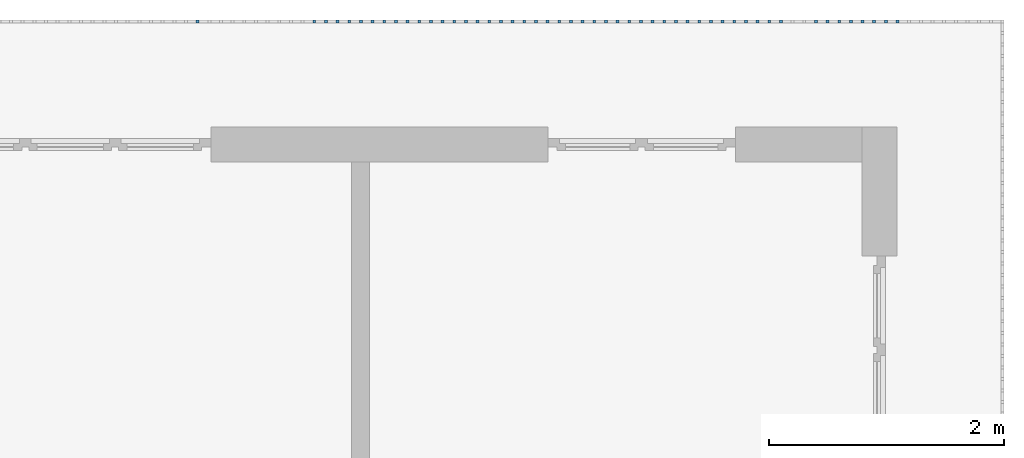
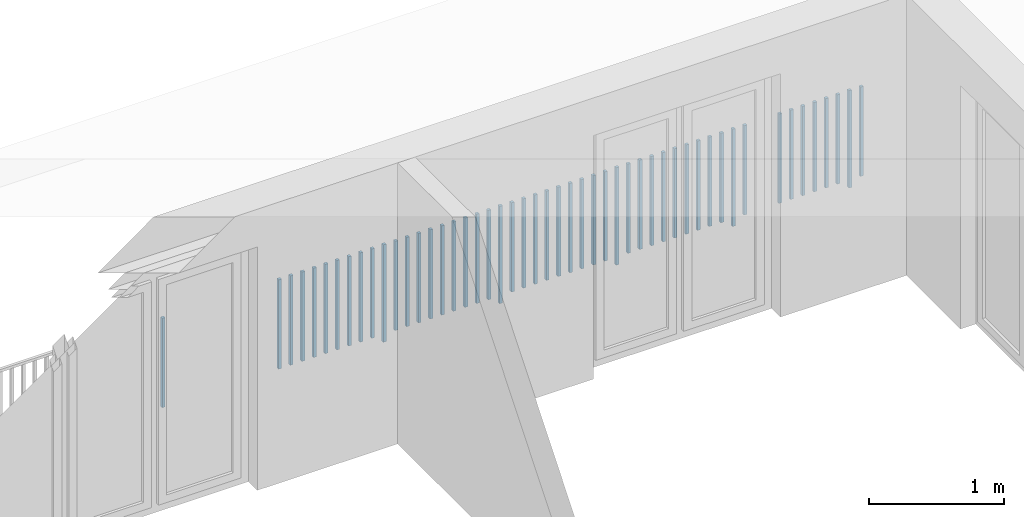
# One storey, part 53 of 54: 50 building element parts, 1 element without a shape of its own.
"""IFC4 building model written with IfcOpenShell, lengths in metres."""

from ifc_helpers import new_model, entity, si_unit, converted_unit, derived_unit, direction, frame, origin_with_axes, place, context, subcontext, project, spatial, polygons, material, type_object, element, aggregate, save


model = new_model("IFC4")

# Units and contexts
model_context = context("Model", 3, precision=1e-05, world=origin_with_axes(), true_north=direction((0.0, 1.0)))
body_context = subcontext(model_context, "Body", "Model", "MODEL_VIEW")
ifc_project = project(units=[si_unit("LENGTHUNIT", "METRE"), si_unit("AREAUNIT", "SQUARE_METRE"), si_unit("VOLUMEUNIT", "CUBIC_METRE"), converted_unit("PLANEANGLEUNIT", "DEGREE", entity("IfcPlaneAngleMeasure", 0.0174532925199), si_unit("PLANEANGLEUNIT", "RADIAN"), dimensions=[0, 0, 0, 0, 0, 0, 0]), converted_unit("TIMEUNIT", "Year", entity("IfcTimeMeasure", 31556926.0), si_unit("TIMEUNIT", "SECOND"), dimensions=[0, 0, 1, 0, 0, 0, 0]), si_unit("MASSUNIT", "GRAM", prefix="KILO"), si_unit("THERMODYNAMICTEMPERATUREUNIT", "DEGREE_CELSIUS"), si_unit("LUMINOUSINTENSITYUNIT", "LUMEN"), si_unit("ENERGYUNIT", "JOULE", prefix="MEGA"), derived_unit("THERMALCONDUCTANCEUNIT", [(si_unit("POWERUNIT", "WATT"), 1), (si_unit("LENGTHUNIT", "METRE"), -1), (si_unit("THERMODYNAMICTEMPERATUREUNIT", "KELVIN"), -1)]), derived_unit("SPECIFICHEATCAPACITYUNIT", [(si_unit("ENERGYUNIT", "JOULE"), 1), (si_unit("MASSUNIT", "GRAM", prefix="KILO"), -1), (si_unit("THERMODYNAMICTEMPERATUREUNIT", "KELVIN"), -1)]), derived_unit("MASSDENSITYUNIT", [(si_unit("MASSUNIT", "GRAM", prefix="KILO"), 1), (si_unit("VOLUMEUNIT", "CUBIC_METRE"), -1)])], contexts=[model_context])

# Site, building, storey, space
site_placement = place(None, origin_with_axes())
site = spatial("IfcSite", under=ifc_project, at=site_placement, CompositionType="ELEMENT")
building_placement = place(site_placement, origin_with_axes())
building = spatial("IfcBuilding", under=site, at=building_placement, CompositionType="ELEMENT")
storey_placement = place(building_placement, frame((0.0, 0.0, 6.29), z_axis=(0.0, 0.0, 1.0), x_axis=(1.0, 0.0, 0.0)))
storey = spatial("IfcBuildingStorey", under=building, at=storey_placement, Name="2. Geschoss", CompositionType="ELEMENT", Elevation=6.29)
space_placement = place(storey_placement, frame((10.2378006196, 9.82118769833, 0.0), z_axis=(0.0, 0.0, 1.0), x_axis=(-1.0, 0.0, 0.0)))
space = spatial("IfcSpace", under=storey, at=space_placement, CompositionType="ELEMENT", PredefinedType="EXTERNAL")

# Railing, building element parts
railing_type = type_object("IfcRailingType", PredefinedType="NOTDEFINED")
railing_placement = place(space_placement, frame((0.0, -7.06315681498e-08, 0.0), z_axis=(0.0, 0.0, 1.0), x_axis=(-1.0, 0.0, 0.0)))
railing = element("IfcRailing", 1, at=railing_placement, inside=space, type_object=railing_type, PredefinedType="NOTDEFINED")
ifc_material = material()
building_element_part_1_placement = place(railing_placement, origin_with_axes())
building_element_part_1 = element("IfcBuildingElementPart", 2, at=building_element_part_1_placement, material=ifc_material, PredefinedType="NOTDEFINED", context=body_context, shape_type="Tessellation", body=[
    polygons([(-0.907804347826, 0.0125, 0.07), (-0.907804347826, -0.0125, 0.07), (-0.907804347826, -0.0125, 0.8775), (-0.907804347826, 0.0125, 0.8775), (-0.882804347826, 0.0125, 0.07), (-0.882804347826, -0.0125, 0.07), (-0.882804347826, -0.0125, 0.8775), (-0.882804347826, 0.0125, 0.8775)], [[[1, 2, 3, 4]], [[1, 5, 6, 2]], [[2, 6, 7, 3]], [[4, 3, 7, 8]], [[5, 1, 4, 8]], [[6, 5, 8, 7]]], closed=True),
])
building_element_part_2_placement = place(railing_placement, origin_with_axes())
building_element_part_2 = element("IfcBuildingElementPart", 3, at=building_element_part_2_placement, material=ifc_material, PredefinedType="NOTDEFINED", context=body_context, shape_type="Tessellation", body=[
    polygons([(-1.0072826087, 0.0125, 0.0), (-1.0072826087, -0.0125, 0.0), (-1.0072826087, -0.0125, 0.88), (-1.0072826087, 0.0125, 0.88), (-0.982282608696, 0.0125, 0.0), (-0.982282608696, -0.0125, 0.0), (-0.982282608696, -0.0125, 0.88), (-0.982282608696, 0.0125, 0.88)], [[[1, 2, 3, 4]], [[1, 5, 6, 2]], [[2, 6, 7, 3]], [[4, 3, 7, 8]], [[5, 1, 4, 8]], [[6, 5, 8, 7]]], closed=True),
])
building_element_part_3_placement = place(railing_placement, origin_with_axes())
building_element_part_3 = element("IfcBuildingElementPart", 4, at=building_element_part_3_placement, material=ifc_material, PredefinedType="NOTDEFINED", context=body_context, shape_type="Tessellation", body=[
    polygons([(-1.10676086957, 0.0125, 0.07), (-1.10676086957, -0.0125, 0.07), (-1.10676086957, -0.0125, 0.8775), (-1.10676086957, 0.0125, 0.8775), (-1.08176086957, 0.0125, 0.07), (-1.08176086957, -0.0125, 0.07), (-1.08176086957, -0.0125, 0.8775), (-1.08176086957, 0.0125, 0.8775)], [[[1, 2, 3, 4]], [[1, 5, 6, 2]], [[2, 6, 7, 3]], [[4, 3, 7, 8]], [[5, 1, 4, 8]], [[6, 5, 8, 7]]], closed=True),
])
building_element_part_4_placement = place(railing_placement, origin_with_axes())
building_element_part_4 = element("IfcBuildingElementPart", 5, at=building_element_part_4_placement, material=ifc_material, PredefinedType="NOTDEFINED", context=body_context, shape_type="Tessellation", body=[
    polygons([(-1.20623913043, 0.0125, 0.07), (-1.20623913043, -0.0125, 0.07), (-1.20623913043, -0.0125, 0.8775), (-1.20623913043, 0.0125, 0.8775), (-1.18123913043, 0.0125, 0.07), (-1.18123913043, -0.0125, 0.07), (-1.18123913043, -0.0125, 0.8775), (-1.18123913043, 0.0125, 0.8775)], [[[1, 2, 3, 4]], [[1, 5, 6, 2]], [[2, 6, 7, 3]], [[4, 3, 7, 8]], [[5, 1, 4, 8]], [[6, 5, 8, 7]]], closed=True),
])
building_element_part_5_placement = place(railing_placement, origin_with_axes())
building_element_part_5 = element("IfcBuildingElementPart", 6, at=building_element_part_5_placement, material=ifc_material, PredefinedType="NOTDEFINED", context=body_context, shape_type="Tessellation", body=[
    polygons([(-1.3057173913, 0.0125, 0.07), (-1.3057173913, -0.0125, 0.07), (-1.3057173913, -0.0125, 0.8775), (-1.3057173913, 0.0125, 0.8775), (-1.2807173913, 0.0125, 0.07), (-1.2807173913, -0.0125, 0.07), (-1.2807173913, -0.0125, 0.8775), (-1.2807173913, 0.0125, 0.8775)], [[[1, 2, 3, 4]], [[1, 5, 6, 2]], [[2, 6, 7, 3]], [[4, 3, 7, 8]], [[5, 1, 4, 8]], [[6, 5, 8, 7]]], closed=True),
])
building_element_part_6_placement = place(railing_placement, origin_with_axes())
building_element_part_6 = element("IfcBuildingElementPart", 7, at=building_element_part_6_placement, material=ifc_material, PredefinedType="NOTDEFINED", context=body_context, shape_type="Tessellation", body=[
    polygons([(-1.40519565217, 0.0125, 0.07), (-1.40519565217, -0.0125, 0.07), (-1.40519565217, -0.0125, 0.8775), (-1.40519565217, 0.0125, 0.8775), (-1.38019565217, 0.0125, 0.07), (-1.38019565217, -0.0125, 0.07), (-1.38019565217, -0.0125, 0.8775), (-1.38019565217, 0.0125, 0.8775)], [[[1, 2, 3, 4]], [[1, 5, 6, 2]], [[2, 6, 7, 3]], [[4, 3, 7, 8]], [[5, 1, 4, 8]], [[6, 5, 8, 7]]], closed=True),
])
building_element_part_7_placement = place(railing_placement, origin_with_axes())
building_element_part_7 = element("IfcBuildingElementPart", 8, at=building_element_part_7_placement, material=ifc_material, PredefinedType="NOTDEFINED", context=body_context, shape_type="Tessellation", body=[
    polygons([(-1.50467391304, 0.0125, 0.07), (-1.50467391304, -0.0125, 0.07), (-1.50467391304, -0.0125, 0.8775), (-1.50467391304, 0.0125, 0.8775), (-1.47967391304, 0.0125, 0.07), (-1.47967391304, -0.0125, 0.07), (-1.47967391304, -0.0125, 0.8775), (-1.47967391304, 0.0125, 0.8775)], [[[1, 2, 3, 4]], [[1, 5, 6, 2]], [[2, 6, 7, 3]], [[4, 3, 7, 8]], [[5, 1, 4, 8]], [[6, 5, 8, 7]]], closed=True),
])
building_element_part_8_placement = place(railing_placement, origin_with_axes())
building_element_part_8 = element("IfcBuildingElementPart", 9, at=building_element_part_8_placement, material=ifc_material, PredefinedType="NOTDEFINED", context=body_context, shape_type="Tessellation", body=[
    polygons([(-1.60415217391, 0.0125, 0.07), (-1.60415217391, -0.0125, 0.07), (-1.60415217391, -0.0125, 0.8775), (-1.60415217391, 0.0125, 0.8775), (-1.57915217391, 0.0125, 0.07), (-1.57915217391, -0.0125, 0.07), (-1.57915217391, -0.0125, 0.8775), (-1.57915217391, 0.0125, 0.8775)], [[[1, 2, 3, 4]], [[1, 5, 6, 2]], [[2, 6, 7, 3]], [[4, 3, 7, 8]], [[5, 1, 4, 8]], [[6, 5, 8, 7]]], closed=True),
])
building_element_part_9_placement = place(railing_placement, origin_with_axes())
building_element_part_9 = element("IfcBuildingElementPart", 10, at=building_element_part_9_placement, material=ifc_material, PredefinedType="NOTDEFINED", context=body_context, shape_type="Tessellation", body=[
    polygons([(-1.90258695652, 0.0125, 0.07), (-1.90258695652, -0.0125, 0.07), (-1.90258695652, -0.0125, 0.8775), (-1.90258695652, 0.0125, 0.8775), (-1.87758695652, 0.0125, 0.07), (-1.87758695652, -0.0125, 0.07), (-1.87758695652, -0.0125, 0.8775), (-1.87758695652, 0.0125, 0.8775)], [[[1, 2, 3, 4]], [[1, 5, 6, 2]], [[2, 6, 7, 3]], [[4, 3, 7, 8]], [[5, 1, 4, 8]], [[6, 5, 8, 7]]], closed=True),
])
building_element_part_10_placement = place(railing_placement, origin_with_axes())
building_element_part_10 = element("IfcBuildingElementPart", 11, at=building_element_part_10_placement, material=ifc_material, PredefinedType="NOTDEFINED", context=body_context, shape_type="Tessellation", body=[
    polygons([(-2.00206521739, 0.0125, 0.0), (-2.00206521739, -0.0125, 0.0), (-2.00206521739, -0.0125, 0.88), (-2.00206521739, 0.0125, 0.88), (-1.97706521739, 0.0125, 0.0), (-1.97706521739, -0.0125, 0.0), (-1.97706521739, -0.0125, 0.88), (-1.97706521739, 0.0125, 0.88)], [[[1, 2, 3, 4]], [[1, 5, 6, 2]], [[2, 6, 7, 3]], [[4, 3, 7, 8]], [[5, 1, 4, 8]], [[6, 5, 8, 7]]], closed=True),
])
building_element_part_11_placement = place(railing_placement, origin_with_axes())
building_element_part_11 = element("IfcBuildingElementPart", 12, at=building_element_part_11_placement, material=ifc_material, PredefinedType="NOTDEFINED", context=body_context, shape_type="Tessellation", body=[
    polygons([(-2.10154347826, 0.0125, 0.07), (-2.10154347826, -0.0125, 0.07), (-2.10154347826, -0.0125, 0.8775), (-2.10154347826, 0.0125, 0.8775), (-2.07654347826, 0.0125, 0.07), (-2.07654347826, -0.0125, 0.07), (-2.07654347826, -0.0125, 0.8775), (-2.07654347826, 0.0125, 0.8775)], [[[1, 2, 3, 4]], [[1, 5, 6, 2]], [[2, 6, 7, 3]], [[4, 3, 7, 8]], [[5, 1, 4, 8]], [[6, 5, 8, 7]]], closed=True),
])
building_element_part_12_placement = place(railing_placement, origin_with_axes())
building_element_part_12 = element("IfcBuildingElementPart", 13, at=building_element_part_12_placement, material=ifc_material, PredefinedType="NOTDEFINED", context=body_context, shape_type="Tessellation", body=[
    polygons([(-2.20102173913, 0.0125, 0.07), (-2.20102173913, -0.0125, 0.07), (-2.20102173913, -0.0125, 0.8775), (-2.20102173913, 0.0125, 0.8775), (-2.17602173913, 0.0125, 0.07), (-2.17602173913, -0.0125, 0.07), (-2.17602173913, -0.0125, 0.8775), (-2.17602173913, 0.0125, 0.8775)], [[[1, 2, 3, 4]], [[1, 5, 6, 2]], [[2, 6, 7, 3]], [[4, 3, 7, 8]], [[5, 1, 4, 8]], [[6, 5, 8, 7]]], closed=True),
])
building_element_part_13_placement = place(railing_placement, origin_with_axes())
building_element_part_13 = element("IfcBuildingElementPart", 14, at=building_element_part_13_placement, material=ifc_material, PredefinedType="NOTDEFINED", context=body_context, shape_type="Tessellation", body=[
    polygons([(-2.3005, 0.0125, 0.07), (-2.3005, -0.0125, 0.07), (-2.3005, -0.0125, 0.8775), (-2.3005, 0.0125, 0.8775), (-2.2755, 0.0125, 0.07), (-2.2755, -0.0125, 0.07), (-2.2755, -0.0125, 0.8775), (-2.2755, 0.0125, 0.8775)], [[[1, 2, 3, 4]], [[1, 5, 6, 2]], [[2, 6, 7, 3]], [[4, 3, 7, 8]], [[5, 1, 4, 8]], [[6, 5, 8, 7]]], closed=True),
])
building_element_part_14_placement = place(railing_placement, origin_with_axes())
building_element_part_14 = element("IfcBuildingElementPart", 15, at=building_element_part_14_placement, material=ifc_material, PredefinedType="NOTDEFINED", context=body_context, shape_type="Tessellation", body=[
    polygons([(-2.39997826087, 0.0125, 0.07), (-2.39997826087, -0.0125, 0.07), (-2.39997826087, -0.0125, 0.8775), (-2.39997826087, 0.0125, 0.8775), (-2.37497826087, 0.0125, 0.07), (-2.37497826087, -0.0125, 0.07), (-2.37497826087, -0.0125, 0.8775), (-2.37497826087, 0.0125, 0.8775)], [[[1, 2, 3, 4]], [[1, 5, 6, 2]], [[2, 6, 7, 3]], [[4, 3, 7, 8]], [[5, 1, 4, 8]], [[6, 5, 8, 7]]], closed=True),
])
building_element_part_15_placement = place(railing_placement, origin_with_axes())
building_element_part_15 = element("IfcBuildingElementPart", 16, at=building_element_part_15_placement, material=ifc_material, PredefinedType="NOTDEFINED", context=body_context, shape_type="Tessellation", body=[
    polygons([(-2.49945652174, 0.0125, 0.07), (-2.49945652174, -0.0125, 0.07), (-2.49945652174, -0.0125, 0.8775), (-2.49945652174, 0.0125, 0.8775), (-2.47445652174, 0.0125, 0.07), (-2.47445652174, -0.0125, 0.07), (-2.47445652174, -0.0125, 0.8775), (-2.47445652174, 0.0125, 0.8775)], [[[1, 2, 3, 4]], [[1, 5, 6, 2]], [[2, 6, 7, 3]], [[4, 3, 7, 8]], [[5, 1, 4, 8]], [[6, 5, 8, 7]]], closed=True),
])
building_element_part_16_placement = place(railing_placement, origin_with_axes())
building_element_part_16 = element("IfcBuildingElementPart", 17, at=building_element_part_16_placement, material=ifc_material, PredefinedType="NOTDEFINED", context=body_context, shape_type="Tessellation", body=[
    polygons([(-2.59893478261, 0.0125, 0.07), (-2.59893478261, -0.0125, 0.07), (-2.59893478261, -0.0125, 0.8775), (-2.59893478261, 0.0125, 0.8775), (-2.57393478261, 0.0125, 0.07), (-2.57393478261, -0.0125, 0.07), (-2.57393478261, -0.0125, 0.8775), (-2.57393478261, 0.0125, 0.8775)], [[[1, 2, 3, 4]], [[1, 5, 6, 2]], [[2, 6, 7, 3]], [[4, 3, 7, 8]], [[5, 1, 4, 8]], [[6, 5, 8, 7]]], closed=True),
])
building_element_part_17_placement = place(railing_placement, origin_with_axes())
building_element_part_17 = element("IfcBuildingElementPart", 18, at=building_element_part_17_placement, material=ifc_material, PredefinedType="NOTDEFINED", context=body_context, shape_type="Tessellation", body=[
    polygons([(-2.69841304348, 0.0125, 0.07), (-2.69841304348, -0.0125, 0.07), (-2.69841304348, -0.0125, 0.8775), (-2.69841304348, 0.0125, 0.8775), (-2.67341304348, 0.0125, 0.07), (-2.67341304348, -0.0125, 0.07), (-2.67341304348, -0.0125, 0.8775), (-2.67341304348, 0.0125, 0.8775)], [[[1, 2, 3, 4]], [[1, 5, 6, 2]], [[2, 6, 7, 3]], [[4, 3, 7, 8]], [[5, 1, 4, 8]], [[6, 5, 8, 7]]], closed=True),
])
building_element_part_18_placement = place(railing_placement, origin_with_axes())
building_element_part_18 = element("IfcBuildingElementPart", 19, at=building_element_part_18_placement, material=ifc_material, PredefinedType="NOTDEFINED", context=body_context, shape_type="Tessellation", body=[
    polygons([(-2.79789130435, 0.0125, 0.07), (-2.79789130435, -0.0125, 0.07), (-2.79789130435, -0.0125, 0.8775), (-2.79789130435, 0.0125, 0.8775), (-2.77289130435, 0.0125, 0.07), (-2.77289130435, -0.0125, 0.07), (-2.77289130435, -0.0125, 0.8775), (-2.77289130435, 0.0125, 0.8775)], [[[1, 2, 3, 4]], [[1, 5, 6, 2]], [[2, 6, 7, 3]], [[4, 3, 7, 8]], [[5, 1, 4, 8]], [[6, 5, 8, 7]]], closed=True),
])
building_element_part_19_placement = place(railing_placement, origin_with_axes())
building_element_part_19 = element("IfcBuildingElementPart", 20, at=building_element_part_19_placement, material=ifc_material, PredefinedType="NOTDEFINED", context=body_context, shape_type="Tessellation", body=[
    polygons([(-2.89736956522, 0.0125, 0.07), (-2.89736956522, -0.0125, 0.07), (-2.89736956522, -0.0125, 0.8775), (-2.89736956522, 0.0125, 0.8775), (-2.87236956522, 0.0125, 0.07), (-2.87236956522, -0.0125, 0.07), (-2.87236956522, -0.0125, 0.8775), (-2.87236956522, 0.0125, 0.8775)], [[[1, 2, 3, 4]], [[1, 5, 6, 2]], [[2, 6, 7, 3]], [[4, 3, 7, 8]], [[5, 1, 4, 8]], [[6, 5, 8, 7]]], closed=True),
])
building_element_part_20_placement = place(railing_placement, origin_with_axes())
building_element_part_20 = element("IfcBuildingElementPart", 21, at=building_element_part_20_placement, material=ifc_material, PredefinedType="NOTDEFINED", context=body_context, shape_type="Tessellation", body=[
    polygons([(-2.99684782609, 0.0125, 0.0), (-2.99684782609, -0.0125, 0.0), (-2.99684782609, -0.0125, 0.88), (-2.99684782609, 0.0125, 0.88), (-2.97184782609, 0.0125, 0.0), (-2.97184782609, -0.0125, 0.0), (-2.97184782609, -0.0125, 0.88), (-2.97184782609, 0.0125, 0.88)], [[[1, 2, 3, 4]], [[1, 5, 6, 2]], [[2, 6, 7, 3]], [[4, 3, 7, 8]], [[5, 1, 4, 8]], [[6, 5, 8, 7]]], closed=True),
])
building_element_part_21_placement = place(railing_placement, origin_with_axes())
building_element_part_21 = element("IfcBuildingElementPart", 22, at=building_element_part_21_placement, material=ifc_material, PredefinedType="NOTDEFINED", context=body_context, shape_type="Tessellation", body=[
    polygons([(-3.09632608696, 0.0125, 0.07), (-3.09632608696, -0.0125, 0.07), (-3.09632608696, -0.0125, 0.8775), (-3.09632608696, 0.0125, 0.8775), (-3.07132608696, 0.0125, 0.07), (-3.07132608696, -0.0125, 0.07), (-3.07132608696, -0.0125, 0.8775), (-3.07132608696, 0.0125, 0.8775)], [[[1, 2, 3, 4]], [[1, 5, 6, 2]], [[2, 6, 7, 3]], [[4, 3, 7, 8]], [[5, 1, 4, 8]], [[6, 5, 8, 7]]], closed=True),
])
building_element_part_22_placement = place(railing_placement, origin_with_axes())
building_element_part_22 = element("IfcBuildingElementPart", 23, at=building_element_part_22_placement, material=ifc_material, PredefinedType="NOTDEFINED", context=body_context, shape_type="Tessellation", body=[
    polygons([(-3.19580434783, 0.0125, 0.07), (-3.19580434783, -0.0125, 0.07), (-3.19580434783, -0.0125, 0.8775), (-3.19580434783, 0.0125, 0.8775), (-3.17080434783, 0.0125, 0.07), (-3.17080434783, -0.0125, 0.07), (-3.17080434783, -0.0125, 0.8775), (-3.17080434783, 0.0125, 0.8775)], [[[1, 2, 3, 4]], [[1, 5, 6, 2]], [[2, 6, 7, 3]], [[4, 3, 7, 8]], [[5, 1, 4, 8]], [[6, 5, 8, 7]]], closed=True),
])
building_element_part_23_placement = place(railing_placement, origin_with_axes())
building_element_part_23 = element("IfcBuildingElementPart", 24, at=building_element_part_23_placement, material=ifc_material, PredefinedType="NOTDEFINED", context=body_context, shape_type="Tessellation", body=[
    polygons([(-3.2952826087, 0.0125, 0.07), (-3.2952826087, -0.0125, 0.07), (-3.2952826087, -0.0125, 0.8775), (-3.2952826087, 0.0125, 0.8775), (-3.2702826087, 0.0125, 0.07), (-3.2702826087, -0.0125, 0.07), (-3.2702826087, -0.0125, 0.8775), (-3.2702826087, 0.0125, 0.8775)], [[[1, 2, 3, 4]], [[1, 5, 6, 2]], [[2, 6, 7, 3]], [[4, 3, 7, 8]], [[5, 1, 4, 8]], [[6, 5, 8, 7]]], closed=True),
])
building_element_part_24_placement = place(railing_placement, origin_with_axes())
building_element_part_24 = element("IfcBuildingElementPart", 25, at=building_element_part_24_placement, material=ifc_material, PredefinedType="NOTDEFINED", context=body_context, shape_type="Tessellation", body=[
    polygons([(-3.39476086957, 0.0125, 0.07), (-3.39476086957, -0.0125, 0.07), (-3.39476086957, -0.0125, 0.8775), (-3.39476086957, 0.0125, 0.8775), (-3.36976086957, 0.0125, 0.07), (-3.36976086957, -0.0125, 0.07), (-3.36976086957, -0.0125, 0.8775), (-3.36976086957, 0.0125, 0.8775)], [[[1, 2, 3, 4]], [[1, 5, 6, 2]], [[2, 6, 7, 3]], [[4, 3, 7, 8]], [[5, 1, 4, 8]], [[6, 5, 8, 7]]], closed=True),
])
building_element_part_25_placement = place(railing_placement, origin_with_axes())
building_element_part_25 = element("IfcBuildingElementPart", 26, at=building_element_part_25_placement, material=ifc_material, PredefinedType="NOTDEFINED", context=body_context, shape_type="Tessellation", body=[
    polygons([(-3.49423913043, 0.0125, 0.07), (-3.49423913043, -0.0125, 0.07), (-3.49423913043, -0.0125, 0.8775), (-3.49423913043, 0.0125, 0.8775), (-3.46923913043, 0.0125, 0.07), (-3.46923913043, -0.0125, 0.07), (-3.46923913043, -0.0125, 0.8775), (-3.46923913043, 0.0125, 0.8775)], [[[1, 2, 3, 4]], [[1, 5, 6, 2]], [[2, 6, 7, 3]], [[4, 3, 7, 8]], [[5, 1, 4, 8]], [[6, 5, 8, 7]]], closed=True),
])
building_element_part_26_placement = place(railing_placement, origin_with_axes())
building_element_part_26 = element("IfcBuildingElementPart", 27, at=building_element_part_26_placement, material=ifc_material, PredefinedType="NOTDEFINED", context=body_context, shape_type="Tessellation", body=[
    polygons([(-3.5937173913, 0.0125, 0.07), (-3.5937173913, -0.0125, 0.07), (-3.5937173913, -0.0125, 0.8775), (-3.5937173913, 0.0125, 0.8775), (-3.5687173913, 0.0125, 0.07), (-3.5687173913, -0.0125, 0.07), (-3.5687173913, -0.0125, 0.8775), (-3.5687173913, 0.0125, 0.8775)], [[[1, 2, 3, 4]], [[1, 5, 6, 2]], [[2, 6, 7, 3]], [[4, 3, 7, 8]], [[5, 1, 4, 8]], [[6, 5, 8, 7]]], closed=True),
])
building_element_part_27_placement = place(railing_placement, origin_with_axes())
building_element_part_27 = element("IfcBuildingElementPart", 28, at=building_element_part_27_placement, material=ifc_material, PredefinedType="NOTDEFINED", context=body_context, shape_type="Tessellation", body=[
    polygons([(-3.69319565217, 0.0125, 0.07), (-3.69319565217, -0.0125, 0.07), (-3.69319565217, -0.0125, 0.8775), (-3.69319565217, 0.0125, 0.8775), (-3.66819565217, 0.0125, 0.07), (-3.66819565217, -0.0125, 0.07), (-3.66819565217, -0.0125, 0.8775), (-3.66819565217, 0.0125, 0.8775)], [[[1, 2, 3, 4]], [[1, 5, 6, 2]], [[2, 6, 7, 3]], [[4, 3, 7, 8]], [[5, 1, 4, 8]], [[6, 5, 8, 7]]], closed=True),
])
building_element_part_28_placement = place(railing_placement, origin_with_axes())
building_element_part_28 = element("IfcBuildingElementPart", 29, at=building_element_part_28_placement, material=ifc_material, PredefinedType="NOTDEFINED", context=body_context, shape_type="Tessellation", body=[
    polygons([(-3.79267391304, 0.0125, 0.07), (-3.79267391304, -0.0125, 0.07), (-3.79267391304, -0.0125, 0.8775), (-3.79267391304, 0.0125, 0.8775), (-3.76767391304, 0.0125, 0.07), (-3.76767391304, -0.0125, 0.07), (-3.76767391304, -0.0125, 0.8775), (-3.76767391304, 0.0125, 0.8775)], [[[1, 2, 3, 4]], [[1, 5, 6, 2]], [[2, 6, 7, 3]], [[4, 3, 7, 8]], [[5, 1, 4, 8]], [[6, 5, 8, 7]]], closed=True),
])
building_element_part_29_placement = place(railing_placement, origin_with_axes())
building_element_part_29 = element("IfcBuildingElementPart", 30, at=building_element_part_29_placement, material=ifc_material, PredefinedType="NOTDEFINED", context=body_context, shape_type="Tessellation", body=[
    polygons([(-3.89215217391, 0.0125, 0.07), (-3.89215217391, -0.0125, 0.07), (-3.89215217391, -0.0125, 0.8775), (-3.89215217391, 0.0125, 0.8775), (-3.86715217391, 0.0125, 0.07), (-3.86715217391, -0.0125, 0.07), (-3.86715217391, -0.0125, 0.8775), (-3.86715217391, 0.0125, 0.8775)], [[[1, 2, 3, 4]], [[1, 5, 6, 2]], [[2, 6, 7, 3]], [[4, 3, 7, 8]], [[5, 1, 4, 8]], [[6, 5, 8, 7]]], closed=True),
])
building_element_part_30_placement = place(railing_placement, origin_with_axes())
building_element_part_30 = element("IfcBuildingElementPart", 31, at=building_element_part_30_placement, material=ifc_material, PredefinedType="NOTDEFINED", context=body_context, shape_type="Tessellation", body=[
    polygons([(-3.99163043478, 0.0125, 0.0), (-3.99163043478, -0.0125, 0.0), (-3.99163043478, -0.0125, 0.88), (-3.99163043478, 0.0125, 0.88), (-3.96663043478, 0.0125, 0.0), (-3.96663043478, -0.0125, 0.0), (-3.96663043478, -0.0125, 0.88), (-3.96663043478, 0.0125, 0.88)], [[[1, 2, 3, 4]], [[1, 5, 6, 2]], [[2, 6, 7, 3]], [[4, 3, 7, 8]], [[5, 1, 4, 8]], [[6, 5, 8, 7]]], closed=True),
])
building_element_part_31_placement = place(railing_placement, origin_with_axes())
building_element_part_31 = element("IfcBuildingElementPart", 32, at=building_element_part_31_placement, material=ifc_material, PredefinedType="NOTDEFINED", context=body_context, shape_type="Tessellation", body=[
    polygons([(-4.09110869565, 0.0125, 0.07), (-4.09110869565, -0.0125, 0.07), (-4.09110869565, -0.0125, 0.8775), (-4.09110869565, 0.0125, 0.8775), (-4.06610869565, 0.0125, 0.07), (-4.06610869565, -0.0125, 0.07), (-4.06610869565, -0.0125, 0.8775), (-4.06610869565, 0.0125, 0.8775)], [[[1, 2, 3, 4]], [[1, 5, 6, 2]], [[2, 6, 7, 3]], [[4, 3, 7, 8]], [[5, 1, 4, 8]], [[6, 5, 8, 7]]], closed=True),
])
building_element_part_32_placement = place(railing_placement, origin_with_axes())
building_element_part_32 = element("IfcBuildingElementPart", 33, at=building_element_part_32_placement, material=ifc_material, PredefinedType="NOTDEFINED", context=body_context, shape_type="Tessellation", body=[
    polygons([(-4.19058695652, 0.0125, 0.07), (-4.19058695652, -0.0125, 0.07), (-4.19058695652, -0.0125, 0.8775), (-4.19058695652, 0.0125, 0.8775), (-4.16558695652, 0.0125, 0.07), (-4.16558695652, -0.0125, 0.07), (-4.16558695652, -0.0125, 0.8775), (-4.16558695652, 0.0125, 0.8775)], [[[1, 2, 3, 4]], [[1, 5, 6, 2]], [[2, 6, 7, 3]], [[4, 3, 7, 8]], [[5, 1, 4, 8]], [[6, 5, 8, 7]]], closed=True),
])
building_element_part_33_placement = place(railing_placement, origin_with_axes())
building_element_part_33 = element("IfcBuildingElementPart", 34, at=building_element_part_33_placement, material=ifc_material, PredefinedType="NOTDEFINED", context=body_context, shape_type="Tessellation", body=[
    polygons([(-4.29006521739, 0.0125, 0.07), (-4.29006521739, -0.0125, 0.07), (-4.29006521739, -0.0125, 0.8775), (-4.29006521739, 0.0125, 0.8775), (-4.26506521739, 0.0125, 0.07), (-4.26506521739, -0.0125, 0.07), (-4.26506521739, -0.0125, 0.8775), (-4.26506521739, 0.0125, 0.8775)], [[[1, 2, 3, 4]], [[1, 5, 6, 2]], [[2, 6, 7, 3]], [[4, 3, 7, 8]], [[5, 1, 4, 8]], [[6, 5, 8, 7]]], closed=True),
])
building_element_part_34_placement = place(railing_placement, origin_with_axes())
building_element_part_34 = element("IfcBuildingElementPart", 35, at=building_element_part_34_placement, material=ifc_material, PredefinedType="NOTDEFINED", context=body_context, shape_type="Tessellation", body=[
    polygons([(-4.38954347826, 0.0125, 0.07), (-4.38954347826, -0.0125, 0.07), (-4.38954347826, -0.0125, 0.8775), (-4.38954347826, 0.0125, 0.8775), (-4.36454347826, 0.0125, 0.07), (-4.36454347826, -0.0125, 0.07), (-4.36454347826, -0.0125, 0.8775), (-4.36454347826, 0.0125, 0.8775)], [[[1, 2, 3, 4]], [[1, 5, 6, 2]], [[2, 6, 7, 3]], [[4, 3, 7, 8]], [[5, 1, 4, 8]], [[6, 5, 8, 7]]], closed=True),
])
building_element_part_35_placement = place(railing_placement, origin_with_axes())
building_element_part_35 = element("IfcBuildingElementPart", 36, at=building_element_part_35_placement, material=ifc_material, PredefinedType="NOTDEFINED", context=body_context, shape_type="Tessellation", body=[
    polygons([(-4.48902173913, 0.0125, 0.07), (-4.48902173913, -0.0125, 0.07), (-4.48902173913, -0.0125, 0.8775), (-4.48902173913, 0.0125, 0.8775), (-4.46402173913, 0.0125, 0.07), (-4.46402173913, -0.0125, 0.07), (-4.46402173913, -0.0125, 0.8775), (-4.46402173913, 0.0125, 0.8775)], [[[1, 2, 3, 4]], [[1, 5, 6, 2]], [[2, 6, 7, 3]], [[4, 3, 7, 8]], [[5, 1, 4, 8]], [[6, 5, 8, 7]]], closed=True),
])
building_element_part_36_placement = place(railing_placement, origin_with_axes())
building_element_part_36 = element("IfcBuildingElementPart", 37, at=building_element_part_36_placement, material=ifc_material, PredefinedType="NOTDEFINED", context=body_context, shape_type="Tessellation", body=[
    polygons([(-4.5885, 0.0125, 0.07), (-4.5885, -0.0125, 0.07), (-4.5885, -0.0125, 0.8775), (-4.5885, 0.0125, 0.8775), (-4.5635, 0.0125, 0.07), (-4.5635, -0.0125, 0.07), (-4.5635, -0.0125, 0.8775), (-4.5635, 0.0125, 0.8775)], [[[1, 2, 3, 4]], [[1, 5, 6, 2]], [[2, 6, 7, 3]], [[4, 3, 7, 8]], [[5, 1, 4, 8]], [[6, 5, 8, 7]]], closed=True),
])
building_element_part_37_placement = place(railing_placement, origin_with_axes())
building_element_part_37 = element("IfcBuildingElementPart", 38, at=building_element_part_37_placement, material=ifc_material, PredefinedType="NOTDEFINED", context=body_context, shape_type="Tessellation", body=[
    polygons([(-4.68797826087, 0.0125, 0.07), (-4.68797826087, -0.0125, 0.07), (-4.68797826087, -0.0125, 0.8775), (-4.68797826087, 0.0125, 0.8775), (-4.66297826087, 0.0125, 0.07), (-4.66297826087, -0.0125, 0.07), (-4.66297826087, -0.0125, 0.8775), (-4.66297826087, 0.0125, 0.8775)], [[[1, 2, 3, 4]], [[1, 5, 6, 2]], [[2, 6, 7, 3]], [[4, 3, 7, 8]], [[5, 1, 4, 8]], [[6, 5, 8, 7]]], closed=True),
])
building_element_part_38_placement = place(railing_placement, origin_with_axes())
building_element_part_38 = element("IfcBuildingElementPart", 39, at=building_element_part_38_placement, material=ifc_material, PredefinedType="NOTDEFINED", context=body_context, shape_type="Tessellation", body=[
    polygons([(-4.78745652174, 0.0125, 0.07), (-4.78745652174, -0.0125, 0.07), (-4.78745652174, -0.0125, 0.8775), (-4.78745652174, 0.0125, 0.8775), (-4.76245652174, 0.0125, 0.07), (-4.76245652174, -0.0125, 0.07), (-4.76245652174, -0.0125, 0.8775), (-4.76245652174, 0.0125, 0.8775)], [[[1, 2, 3, 4]], [[1, 5, 6, 2]], [[2, 6, 7, 3]], [[4, 3, 7, 8]], [[5, 1, 4, 8]], [[6, 5, 8, 7]]], closed=True),
])
building_element_part_39_placement = place(railing_placement, origin_with_axes())
building_element_part_39 = element("IfcBuildingElementPart", 40, at=building_element_part_39_placement, material=ifc_material, PredefinedType="NOTDEFINED", context=body_context, shape_type="Tessellation", body=[
    polygons([(-4.88693478261, 0.0125, 0.07), (-4.88693478261, -0.0125, 0.07), (-4.88693478261, -0.0125, 0.8775), (-4.88693478261, 0.0125, 0.8775), (-4.86193478261, 0.0125, 0.07), (-4.86193478261, -0.0125, 0.07), (-4.86193478261, -0.0125, 0.8775), (-4.86193478261, 0.0125, 0.8775)], [[[1, 2, 3, 4]], [[1, 5, 6, 2]], [[2, 6, 7, 3]], [[4, 3, 7, 8]], [[5, 1, 4, 8]], [[6, 5, 8, 7]]], closed=True),
])
building_element_part_40_placement = place(railing_placement, origin_with_axes())
building_element_part_40 = element("IfcBuildingElementPart", 41, at=building_element_part_40_placement, material=ifc_material, PredefinedType="NOTDEFINED", context=body_context, shape_type="Tessellation", body=[
    polygons([(-4.98641304348, 0.0125, 0.0), (-4.98641304348, -0.0125, 0.0), (-4.98641304348, -0.0125, 0.88), (-4.98641304348, 0.0125, 0.88), (-4.96141304348, 0.0125, 0.0), (-4.96141304348, -0.0125, 0.0), (-4.96141304348, -0.0125, 0.88), (-4.96141304348, 0.0125, 0.88)], [[[1, 2, 3, 4]], [[1, 5, 6, 2]], [[2, 6, 7, 3]], [[4, 3, 7, 8]], [[5, 1, 4, 8]], [[6, 5, 8, 7]]], closed=True),
])
building_element_part_41_placement = place(railing_placement, origin_with_axes())
building_element_part_41 = element("IfcBuildingElementPart", 42, at=building_element_part_41_placement, material=ifc_material, PredefinedType="NOTDEFINED", context=body_context, shape_type="Tessellation", body=[
    polygons([(-5.08589130435, 0.0125, 0.07), (-5.08589130435, -0.0125, 0.07), (-5.08589130435, -0.0125, 0.8775), (-5.08589130435, 0.0125, 0.8775), (-5.06089130435, 0.0125, 0.07), (-5.06089130435, -0.0125, 0.07), (-5.06089130435, -0.0125, 0.8775), (-5.06089130435, 0.0125, 0.8775)], [[[1, 2, 3, 4]], [[1, 5, 6, 2]], [[2, 6, 7, 3]], [[4, 3, 7, 8]], [[5, 1, 4, 8]], [[6, 5, 8, 7]]], closed=True),
])
building_element_part_42_placement = place(railing_placement, origin_with_axes())
building_element_part_42 = element("IfcBuildingElementPart", 43, at=building_element_part_42_placement, material=ifc_material, PredefinedType="NOTDEFINED", context=body_context, shape_type="Tessellation", body=[
    polygons([(-5.18536956522, 0.0125, 0.07), (-5.18536956522, -0.0125, 0.07), (-5.18536956522, -0.0125, 0.8775), (-5.18536956522, 0.0125, 0.8775), (-5.16036956522, 0.0125, 0.07), (-5.16036956522, -0.0125, 0.07), (-5.16036956522, -0.0125, 0.8775), (-5.16036956522, 0.0125, 0.8775)], [[[1, 2, 3, 4]], [[1, 5, 6, 2]], [[2, 6, 7, 3]], [[4, 3, 7, 8]], [[5, 1, 4, 8]], [[6, 5, 8, 7]]], closed=True),
])
building_element_part_43_placement = place(railing_placement, origin_with_axes())
building_element_part_43 = element("IfcBuildingElementPart", 44, at=building_element_part_43_placement, material=ifc_material, PredefinedType="NOTDEFINED", context=body_context, shape_type="Tessellation", body=[
    polygons([(-5.28484782609, 0.0125, 0.07), (-5.28484782609, -0.0125, 0.07), (-5.28484782609, -0.0125, 0.8775), (-5.28484782609, 0.0125, 0.8775), (-5.25984782609, 0.0125, 0.07), (-5.25984782609, -0.0125, 0.07), (-5.25984782609, -0.0125, 0.8775), (-5.25984782609, 0.0125, 0.8775)], [[[1, 2, 3, 4]], [[1, 5, 6, 2]], [[2, 6, 7, 3]], [[4, 3, 7, 8]], [[5, 1, 4, 8]], [[6, 5, 8, 7]]], closed=True),
])
building_element_part_44_placement = place(railing_placement, origin_with_axes())
building_element_part_44 = element("IfcBuildingElementPart", 45, at=building_element_part_44_placement, material=ifc_material, PredefinedType="NOTDEFINED", context=body_context, shape_type="Tessellation", body=[
    polygons([(-5.38432608696, 0.0125, 0.07), (-5.38432608696, -0.0125, 0.07), (-5.38432608696, -0.0125, 0.8775), (-5.38432608696, 0.0125, 0.8775), (-5.35932608696, 0.0125, 0.07), (-5.35932608696, -0.0125, 0.07), (-5.35932608696, -0.0125, 0.8775), (-5.35932608696, 0.0125, 0.8775)], [[[1, 2, 3, 4]], [[1, 5, 6, 2]], [[2, 6, 7, 3]], [[4, 3, 7, 8]], [[5, 1, 4, 8]], [[6, 5, 8, 7]]], closed=True),
])
building_element_part_45_placement = place(railing_placement, origin_with_axes())
building_element_part_45 = element("IfcBuildingElementPart", 46, at=building_element_part_45_placement, material=ifc_material, PredefinedType="NOTDEFINED", context=body_context, shape_type="Tessellation", body=[
    polygons([(-5.48380434783, 0.0125, 0.07), (-5.48380434783, -0.0125, 0.07), (-5.48380434783, -0.0125, 0.8775), (-5.48380434783, 0.0125, 0.8775), (-5.45880434783, 0.0125, 0.07), (-5.45880434783, -0.0125, 0.07), (-5.45880434783, -0.0125, 0.8775), (-5.45880434783, 0.0125, 0.8775)], [[[1, 2, 3, 4]], [[1, 5, 6, 2]], [[2, 6, 7, 3]], [[4, 3, 7, 8]], [[5, 1, 4, 8]], [[6, 5, 8, 7]]], closed=True),
])
building_element_part_46_placement = place(railing_placement, origin_with_axes())
building_element_part_46 = element("IfcBuildingElementPart", 47, at=building_element_part_46_placement, material=ifc_material, PredefinedType="NOTDEFINED", context=body_context, shape_type="Tessellation", body=[
    polygons([(-5.5832826087, 0.0125, 0.07), (-5.5832826087, -0.0125, 0.07), (-5.5832826087, -0.0125, 0.8775), (-5.5832826087, 0.0125, 0.8775), (-5.5582826087, 0.0125, 0.07), (-5.5582826087, -0.0125, 0.07), (-5.5582826087, -0.0125, 0.8775), (-5.5582826087, 0.0125, 0.8775)], [[[1, 2, 3, 4]], [[1, 5, 6, 2]], [[2, 6, 7, 3]], [[4, 3, 7, 8]], [[5, 1, 4, 8]], [[6, 5, 8, 7]]], closed=True),
])
building_element_part_47_placement = place(railing_placement, origin_with_axes())
building_element_part_47 = element("IfcBuildingElementPart", 48, at=building_element_part_47_placement, material=ifc_material, PredefinedType="NOTDEFINED", context=body_context, shape_type="Tessellation", body=[
    polygons([(-5.68276086957, 0.0125, 0.07), (-5.68276086957, -0.0125, 0.07), (-5.68276086957, -0.0125, 0.8775), (-5.68276086957, 0.0125, 0.8775), (-5.65776086957, 0.0125, 0.07), (-5.65776086957, -0.0125, 0.07), (-5.65776086957, -0.0125, 0.8775), (-5.65776086957, 0.0125, 0.8775)], [[[1, 2, 3, 4]], [[1, 5, 6, 2]], [[2, 6, 7, 3]], [[4, 3, 7, 8]], [[5, 1, 4, 8]], [[6, 5, 8, 7]]], closed=True),
])
building_element_part_48_placement = place(railing_placement, origin_with_axes())
building_element_part_48 = element("IfcBuildingElementPart", 49, at=building_element_part_48_placement, material=ifc_material, PredefinedType="NOTDEFINED", context=body_context, shape_type="Tessellation", body=[
    polygons([(-5.78223913043, 0.0125, 0.07), (-5.78223913043, -0.0125, 0.07), (-5.78223913043, -0.0125, 0.8775), (-5.78223913043, 0.0125, 0.8775), (-5.75723913043, 0.0125, 0.07), (-5.75723913043, -0.0125, 0.07), (-5.75723913043, -0.0125, 0.8775), (-5.75723913043, 0.0125, 0.8775)], [[[1, 2, 3, 4]], [[1, 5, 6, 2]], [[2, 6, 7, 3]], [[4, 3, 7, 8]], [[5, 1, 4, 8]], [[6, 5, 8, 7]]], closed=True),
])
building_element_part_49_placement = place(railing_placement, origin_with_axes())
building_element_part_49 = element("IfcBuildingElementPart", 50, at=building_element_part_49_placement, material=ifc_material, PredefinedType="NOTDEFINED", context=body_context, shape_type="Tessellation", body=[
    polygons([(-5.8817173913, 0.0125, 0.07), (-5.8817173913, -0.0125, 0.07), (-5.8817173913, -0.0125, 0.8775), (-5.8817173913, 0.0125, 0.8775), (-5.8567173913, 0.0125, 0.07), (-5.8567173913, -0.0125, 0.07), (-5.8567173913, -0.0125, 0.8775), (-5.8567173913, 0.0125, 0.8775)], [[[1, 2, 3, 4]], [[1, 5, 6, 2]], [[2, 6, 7, 3]], [[4, 3, 7, 8]], [[5, 1, 4, 8]], [[6, 5, 8, 7]]], closed=True),
])
building_element_part_50_placement = place(railing_placement, origin_with_axes())
building_element_part_50 = element("IfcBuildingElementPart", 51, at=building_element_part_50_placement, material=ifc_material, PredefinedType="NOTDEFINED", context=body_context, shape_type="Tessellation", body=[
    polygons([(-6.8765, 0.0125, 0.07), (-6.8765, -0.0125, 0.07), (-6.8765, -0.0125, 0.8775), (-6.8765, 0.0125, 0.8775), (-6.8515, 0.0125, 0.07), (-6.8515, -0.0125, 0.07), (-6.8515, -0.0125, 0.8775), (-6.8515, 0.0125, 0.8775)], [[[1, 2, 3, 4]], [[1, 5, 6, 2]], [[2, 6, 7, 3]], [[4, 3, 7, 8]], [[5, 1, 4, 8]], [[6, 5, 8, 7]]], closed=True),
])
aggregate(railing, [building_element_part_1, building_element_part_2, building_element_part_3, building_element_part_4, building_element_part_5, building_element_part_6, building_element_part_7, building_element_part_8, building_element_part_9, building_element_part_10, building_element_part_11, building_element_part_12, building_element_part_13, building_element_part_14, building_element_part_15, building_element_part_16, building_element_part_17, building_element_part_18, building_element_part_19, building_element_part_20, building_element_part_21, building_element_part_22, building_element_part_23, building_element_part_24, building_element_part_25, building_element_part_26, building_element_part_27, building_element_part_28, building_element_part_29, building_element_part_30, building_element_part_31, building_element_part_32, building_element_part_33, building_element_part_34, building_element_part_35, building_element_part_36, building_element_part_37, building_element_part_38, building_element_part_39, building_element_part_40, building_element_part_41, building_element_part_42, building_element_part_43, building_element_part_44, building_element_part_45, building_element_part_46, building_element_part_47, building_element_part_48, building_element_part_49, building_element_part_50])

save(model, "model.ifc")
